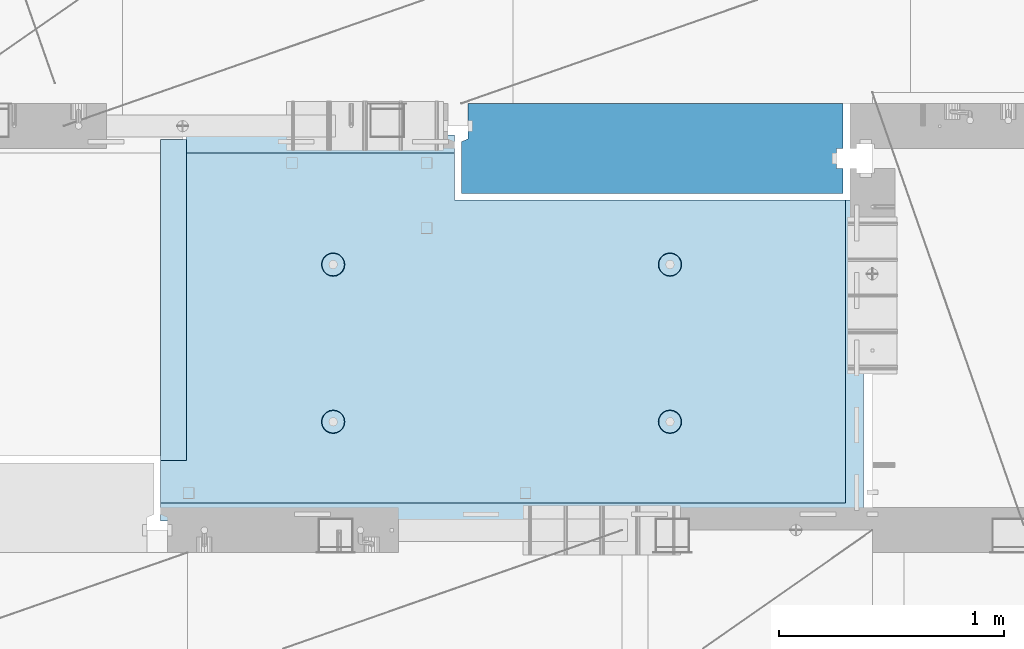
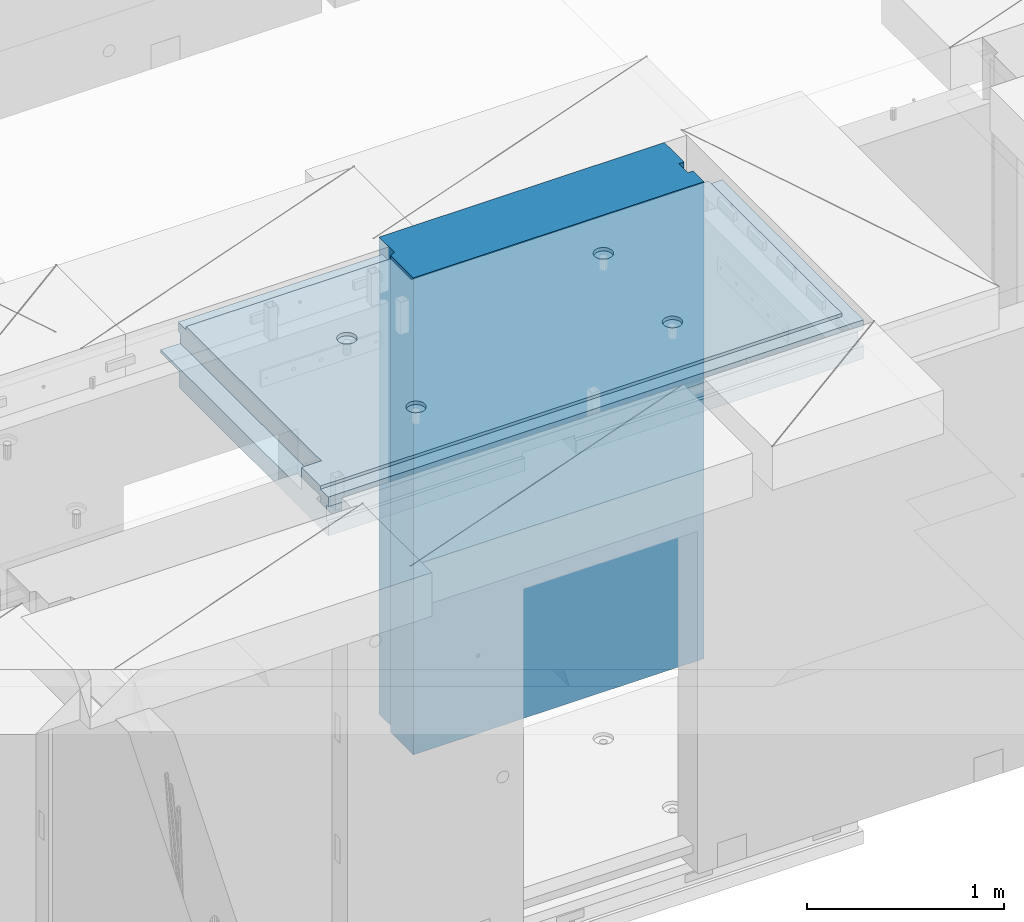
# One storey, part 209 of 352: 1 plate, 1 slab, 2 elements without a shape of their own.
"""IFC2X3 building model written with IfcOpenShell, lengths in millimetres."""

from ifc_helpers import new_model, si_unit, frame, origin_with_axes, place, context, subcontext, project, spatial, faceted_brep, material, type_object, element, aggregate, save


model = new_model("IFC2X3")

# Units and contexts
model_context = context("Model", 3, precision=1e-05, world=origin_with_axes())
body_context = subcontext(model_context, "Body", "Model", "MODEL_VIEW")
ifc_project = project(units=[si_unit("LENGTHUNIT", "METRE", prefix="MILLI"), si_unit("AREAUNIT", "SQUARE_METRE"), si_unit("VOLUMEUNIT", "CUBIC_METRE"), si_unit("MASSUNIT", "GRAM", prefix="KILO"), si_unit("TIMEUNIT", "SECOND"), si_unit("PLANEANGLEUNIT", "RADIAN"), si_unit("SOLIDANGLEUNIT", "STERADIAN"), si_unit("THERMODYNAMICTEMPERATUREUNIT", "DEGREE_CELSIUS"), si_unit("LUMINOUSINTENSITYUNIT", "LUMEN")], contexts=[model_context])

# Site, building, storey
site_placement = place(None, origin_with_axes())
site = spatial("IfcSite", under=ifc_project, at=site_placement, CompositionType="ELEMENT")
building_placement = place(site_placement, origin_with_axes())
building = spatial("IfcBuilding", under=site, at=building_placement, CompositionType="ELEMENT")
storey_placement = place(building_placement, origin_with_axes())
storey = spatial("IfcBuildingStorey", under=building, at=storey_placement, Name="6", CompositionType="ELEMENT", Elevation=0.0)

# Assembly, slab
assembly_1_placement = place(storey_placement, origin_with_axes())
assembly_1 = element("IfcElementAssembly", 1, at=assembly_1_placement, inside=storey, AssemblyPlace="NOTDEFINED", PredefinedType="REINFORCEMENT_UNIT")
ifc_material_1 = material(Name="CONCRETE/C25/30")
slab_type = type_object("IfcSlabType", PredefinedType="NOTDEFINED")
slab_placement = place(assembly_1_placement, frame((26570.0059390845, 15220.0026483125, 99620.0), z_axis=(-0.999999999997437, -2.26400000064461e-06, 0.0), x_axis=(-1.19799915409591e-06, 0.999999999999282, 0.0)))
slab = element("IfcSlab", 2, at=slab_placement, type_object=slab_type, material=ifc_material_1, PredefinedType="FLOOR", context=body_context, shape_type="Brep", body=[
    faceted_brep([(260.000036693442, 30.0, 20.0001116859203), (260.00040878505, 30.0, 210.00282380305), (760.000392750888, 30.0, 210.001882803081), (760.000035167954, 30.0, 20.0003241859195), (259.999997532928, 50.0008466322761, 0.000110715616756352), (259.999997531775, 130.0, 4.72937244921923e-11), (260.00040878505, 130.0, 210.00282380305), (260.00003669344, 50.0008466322906, 20.0001116859239), (760.000392750888, 130.0, 210.001882803081), (759.999997530887, 50.0009701322706, 0.00188280345173553), (760.000035167954, 50.0009701322851, 20.0003241859267), (759.999997530887, 130.0, 1.4915713109076e-10), (0.0, 130.0, -1.81898940354586e-12), (0.0, 50.0007830199902, -3.63797880709171e-12), (2.23492861550767e-06, 50.0007830199902, 20.0000012144774), (0.00314200731554592, 50.0009709416772, 1679.99820316408), (0.00316042736994859, 130.0, 1679.99820316404), (20.0042037197236, 50.0007871208509, 20.0000019346335), (20.0050448999082, 50.0009732451872, 1679.9981655205), (20.0051981998968, 30.0, 1979.99816552074), (210.003723882246, 30.0, 1979.99780794351), (210.003159282247, 30.0, 1679.99780794404), (20.0050448999027, 30.0, 1679.9981655205), (20.0057858500695, 50.0011356208415, 3129.99855788155), (0.00588817475545511, 50.0011356208415, 3129.99536132812), (0.00371018100122456, 50.0010050132987, 1979.99820316354), (20.0051981998986, 50.0010068401461, 1979.99816552074), (1720.00727399273, -49.9988643791585, 3014.99216831216), (1700.0058891816, -49.9988643791585, 3014.99217713277), (1700.0058891816, 9.99999999994179, 3014.99217713277), (270.007273993393, 9.99999999994179, 3014.99280776216), (270.007273993393, -130.000000000058, 3014.99280776216), (1640.00591170533, -130.000000000058, 3014.99220359276), (1640.00591170533, -110.000000000058, 3014.99220359276), (1720.00727399273, -110.000000000058, 3014.99216831216), (1700.00578510373, 9.99999999994179, 3129.99536132812), (270.007324709519, 9.99999999994179, 3129.99536132812), (1700.00588013352, 9.99999999994179, 3024.99005271558), (270.007324709519, -130.0, 3129.99536132812), (0.0, -49.9992169800098, -3.63797880709171e-12), (1.81898940354586e-12, -110.000000000058, 0.0), (0.00588817475545511, -110.0, 3129.99536132812), (0.00588817475545511, -49.9988643791585, 3129.99536132812), (2.27349282795331e-05, -49.9992169800098, 20.000001214441), (40.0000000237706, -110.0, 0.00323799208854325), (40.0000056179106, -110.0, 80.000116817555), (80.0001648500238, -110.0, 80.0001140175445), (80.0058896111077, -110.0, 3129.99536132811), (80.0001648500238, -130.0, 80.0001140175445), (80.0058896111077, -130.0, 3129.99536132812), (458.262860973307, -110.000000000015, 813.90255309167), (472.201273869185, -110.000000000015, 821.004529187678), (483.262860973307, -110.000000000015, 832.066116291804), (490.364837069317, -110.000000000015, 846.004529187678), (492.812011254558, -110.000000000015, 861.455378906427), (490.364837069317, -110.000000000015, 876.906228625172), (483.262860973307, -110.000000000015, 890.844641521049), (472.201273869185, -110.000000000015, 901.906228625176), (458.262860973306, -110.000000000015, 909.008204721184), (442.81201125456, -110.000000000015, 911.455378906427), (427.361161535811, -110.000000000015, 909.008204721184), (413.422748639936, -110.000000000015, 901.906228625176), (402.361161535813, -110.000000000015, 890.844641521046), (395.259185439802, -110.000000000015, 876.906228625176), (392.81201125456, -110.000000000015, 861.455378906427), (395.259185439802, -110.000000000015, 846.004529187681), (402.361161535813, -110.000000000015, 832.0661162918), (413.422748639936, -110.000000000015, 821.004529187678), (427.361161535813, -110.000000000015, 813.90255309167), (442.812011254558, -110.000000000015, 811.455378906427), (458.965172324157, -130.0, 811.741061009179), (442.812011254558, -130.0, 809.182651633699), (473.537149442574, -130.0, 819.165854200462), (485.101535960521, -130.0, 830.730240718414), (492.526329151806, -130.0, 845.302217836826), (495.084738527285, -130.0, 861.45537890643), (492.526329151804, -130.0, 877.608539976027), (485.101535960521, -130.0, 892.180517094443), (473.537149442574, -130.0, 903.744903612387), (458.965172324157, -130.0, 911.16969680367), (442.81201125456, -130.0, 913.728106179151), (426.658850184962, -130.0, 911.169696803674), (412.086873066544, -130.0, 903.744903612391), (400.522486548598, -130.0, 892.180517094443), (393.097693357315, -130.0, 877.608539976027), (390.539283981834, -130.0, 861.455378906427), (393.097693357317, -130.0, 845.302217836826), (400.522486548598, -130.0, 830.730240718414), (412.086873066544, -130.0, 819.165854200462), (426.658850184962, -130.0, 811.741061009183), (1158.26361347154, -110.000000000058, 2313.90608356011), (1172.20202636741, -110.000000000058, 2321.00805965612), (1183.26361347154, -110.000000000058, 2332.06964676024), (1190.36558956755, -110.000000000058, 2346.00805965611), (1192.81276375279, -110.000000000058, 2361.45890937486), (1190.36558956755, -110.000000000058, 2376.90975909361), (1183.26361347154, -110.000000000058, 2390.84817198949), (1172.20202636741, -110.000000000058, 2401.90975909361), (1158.26361347154, -110.000000000058, 2409.01173518962), (1142.81276375279, -110.000000000058, 2411.45890937487), (1127.36191403404, -110.000000000058, 2409.01173518962), (1113.42350113817, -110.000000000058, 2401.90975909361), (1102.36191403404, -110.000000000058, 2390.84817198948), (1095.25993793803, -110.000000000058, 2376.90975909361), (1092.81276375279, -110.000000000058, 2361.45890937486), (1095.25993793803, -110.000000000058, 2346.00805965612), (1102.36191403404, -110.000000000058, 2332.06964676024), (1113.42350113817, -110.000000000058, 2321.00805965611), (1127.36191403405, -110.000000000058, 2313.90608356011), (1142.81276375279, -110.000000000058, 2311.45890937486), (1158.96592482239, -130.000000000044, 2311.74459147762), (1142.81276375279, -130.000000000044, 2309.18618210214), (1173.5379019408, -130.000000000044, 2319.1693846689), (1185.10228845875, -130.000000000044, 2330.73377118685), (1192.52708165004, -130.000000000044, 2345.30574830526), (1195.08549102551, -130.000000000044, 2361.45890937486), (1192.52708165004, -130.000000000044, 2377.61207044447), (1185.10228845875, -130.000000000044, 2392.18404756288), (1173.5379019408, -130.000000000044, 2403.74843408083), (1158.96592482239, -130.000000000044, 2411.17322727211), (1142.81276375279, -130.000000000044, 2413.73163664759), (1126.65960268319, -130.000000000044, 2411.17322727211), (1112.08762556478, -130.000000000044, 2403.74843408083), (1100.52323904683, -130.000000000044, 2392.18404756287), (1093.09844585554, -130.000000000044, 2377.61207044447), (1090.54003648007, -130.000000000044, 2361.45890937486), (1093.09844585555, -130.000000000044, 2345.30574830526), (1100.52323904683, -130.000000000044, 2330.73377118685), (1112.08762556478, -130.000000000044, 2319.1693846689), (1126.65960268319, -130.000000000044, 2311.74459147762), (1158.26322681425, -110.000000000029, 813.902566246979), (1172.20163971013, -110.000000000029, 821.004542342987), (1183.26322681425, -110.000000000029, 832.066129447114), (1190.36520291026, -110.000000000029, 846.004542342987), (1192.8123770955, -110.000000000029, 861.455392061736), (1190.36520291026, -110.000000000029, 876.906241780482), (1183.26322681425, -110.000000000029, 890.844654676363), (1172.20163971012, -110.000000000029, 901.906241780485), (1158.26322681425, -110.000000000029, 909.008217876493), (1142.8123770955, -110.000000000029, 911.455392061736), (1127.36152737675, -110.000000000029, 909.008217876493), (1113.42311448088, -110.000000000029, 901.906241780485), (1102.36152737675, -110.000000000029, 890.844654676359), (1095.25955128074, -110.000000000029, 876.906241780485), (1092.8123770955, -110.000000000029, 861.45539206174), (1095.25955128074, -110.000000000029, 846.004542342991), (1102.36152737675, -110.000000000029, 832.06612944711), (1113.42311448088, -110.000000000029, 821.004542342987), (1127.36152737675, -110.000000000029, 813.902566246979), (1142.8123770955, -110.000000000029, 811.455392061736), (1158.9655381651, -130.000000000029, 811.741074164489), (1142.8123770955, -130.000000000029, 809.182664789012), (1173.53751528352, -130.000000000029, 819.165867355772), (1185.10190180146, -130.000000000029, 830.730253873724), (1192.52669499275, -130.000000000029, 845.302230992136), (1195.08510436823, -130.000000000029, 861.45539206174), (1192.52669499275, -130.000000000029, 877.608553131337), (1185.10190180146, -130.000000000029, 892.180530249756), (1173.53751528351, -130.000000000029, 903.744916767697), (1158.9655381651, -130.000000000029, 911.16970995898), (1142.8123770955, -130.000000000029, 913.728119334461), (1126.6592160259, -130.000000000029, 911.169709958984), (1112.08723890749, -130.000000000029, 903.7449167677), (1100.52285238954, -130.000000000029, 892.180530249752), (1093.09805919825, -130.000000000029, 877.608553131337), (1090.53964982277, -130.000000000015, 861.455392061736), (1093.09805919826, -130.000000000015, 845.302230992136), (1100.52285238954, -130.000000000015, 830.730253873724), (1112.08723890749, -130.000000000015, 819.165867355776), (1126.6592160259, -130.000000000015, 811.741074164493), (458.263613472778, -110.000000000058, 2313.90740096011), (472.202026368655, -110.000000000058, 2321.00937705611), (483.263613472776, -110.000000000058, 2332.07096416024), (490.365589568788, -110.000000000058, 2346.00937705611), (492.812763754029, -110.000000000058, 2361.46022677486), (490.365589568788, -110.000000000058, 2376.91107649361), (483.263613472778, -110.000000000058, 2390.84948938949), (472.202026368655, -110.000000000058, 2401.91107649361), (458.263613472776, -110.000000000058, 2409.01305258962), (442.812763754029, -110.000000000058, 2411.46022677486), (427.361914035282, -110.000000000058, 2409.01305258962), (413.423501139407, -110.000000000058, 2401.91107649361), (402.361914035284, -110.000000000058, 2390.84948938949), (395.259937939272, -110.000000000058, 2376.91107649361), (392.812763754031, -110.000000000058, 2361.46022677486), (395.259937939272, -110.000000000058, 2346.00937705612), (402.361914035284, -110.000000000058, 2332.07096416024), (413.423501139407, -110.000000000058, 2321.00937705611), (427.361914035284, -110.000000000058, 2313.90740096011), (442.812763754029, -110.000000000058, 2311.46022677486), (458.965924823628, -130.000000000029, 2311.74590887762), (442.812763754029, -130.000000000029, 2309.18749950214), (473.537901942043, -130.000000000029, 2319.1707020689), (485.10228845999, -130.000000000029, 2330.73508858685), (492.527081651273, -130.000000000029, 2345.30706570526), (495.085491026754, -130.000000000029, 2361.46022677486), (492.527081651273, -130.000000000029, 2377.61338784446), (485.102288459992, -130.000000000029, 2392.18536496288), (473.537901942043, -130.000000000029, 2403.74975148082), (458.965924823628, -130.000000000029, 2411.1745446721), (442.812763754031, -130.000000000029, 2413.73295404758), (426.659602684433, -130.000000000029, 2411.17454467211), (412.087625566017, -130.000000000029, 2403.74975148082), (400.523239048071, -130.000000000029, 2392.18536496288), (393.098445856787, -130.000000000029, 2377.61338784446), (390.540036481307, -130.000000000029, 2361.46022677486), (393.098445856789, -130.000000000029, 2345.30706570526), (400.523239048067, -130.000000000029, 2330.73508858685), (412.087625566017, -130.000000000029, 2319.17070206891), (426.659602684433, -130.000000000029, 2311.74590887762), (1640.0069692709, -130.000000000058, 1820.00285259458), (1429.99412576448, -130.0, 80.0005450159842), (1430.00077693619, -130.000000000044, 1820.00324782623), (1640.0069692709, -110.000000000058, 1820.00285259458), (1720.00719314726, -110.000000000058, 1820.00270203416), (1720.00719416424, -49.9988643791585, 1820.00270203415), (1700.00697064704, -49.9988643791585, 1820.00273967458), (1430.00077693619, 129.999999999985, 1820.00324782623), (1720.00507313573, 130.0, 1820.00270203815), (1720.00696350816, 50.0011356208415, 1820.00270203459), (1700.00697064704, 50.0011356208415, 1820.00273967458), (1720.00548380367, 130.0, 2629.9953613439), (1720.00479630696, 50.0011356208415, 2629.99536134425), (1700.00623760369, 50.0011356208415, 2629.99539898154), (1700.00623760369, 30.0, 2629.99539898154), (1700.00578510373, 30.0, 3129.99535793147), (1510.00479630733, 130.0, 2629.99575656425), (1510.00479630733, 30.0, 2629.99575656425), (1510.00573730659, 130.0, 3129.99536132812), (1510.00573730659, 30.0, 3129.99536134176), (0.00588817475545511, 130.0, 3129.99536132812), (20.0057858500695, -49.9988643791585, 3129.99855788155), (0.00372479000361636, 130.0, 1979.99820316351), (210.003723882246, 130.0, 1979.99780794351), (210.003159282247, 130.0, 1679.99780794404), (20.0042037196527, -49.9988643791585, 20.0000019345935), (20.0041864226587, -49.9992128791491, 7.34271452529356e-07), (1429.99419217423, -49.9988643791585, 20.0006089333838), (1429.99420067423, -49.9988643791585, 0.000608933383773547), (80.0000146155362, -110.0, 0.000114017555461032), (1429.99735169022, -110.0, 7.40013310860377e-05), (1429.99412576448, -110.0, 80.0005450159842), (1429.99416747423, 50.0011356208415, 20.0006089334311), (1429.99417597423, 50.0011356208415, 0.000608933431067271), (1429.99735169022, 130.0, 2.80124368146062e-10), (20.0041864225386, 50.0007871208509, -3.03407432511449e-09)], [[[0, 1, 2, 3]], [[4, 5, 6, 1, 0, 7]], [[8, 2, 1, 6]], [[9, 10, 3, 2, 8, 11]], [[12, 13, 14, 15, 16]], [[14, 17, 18, 15]], [[19, 20, 21, 22]], [[23, 24, 25, 26]], [[27, 28, 29, 30, 31, 32, 33, 34]], [[35, 36, 30, 29, 37]], [[31, 30, 36, 38]], [[39, 40, 41, 42, 43]], [[44, 45, 46, 47, 41, 40]], [[48, 49, 47, 46]], [[50, 51, 52, 53, 54, 55, 56, 57, 58, 59, 60, 61, 62, 63, 64, 65, 66, 67, 68, 69]], [[70, 50, 69, 71]], [[72, 51, 50, 70]], [[73, 52, 51, 72]], [[74, 53, 52, 73]], [[75, 54, 53, 74]], [[76, 55, 54, 75]], [[77, 56, 55, 76]], [[78, 57, 56, 77]], [[79, 58, 57, 78]], [[80, 59, 58, 79]], [[81, 60, 59, 80]], [[82, 61, 60, 81]], [[83, 62, 61, 82]], [[84, 63, 62, 83]], [[85, 64, 63, 84]], [[86, 65, 64, 85]], [[87, 66, 65, 86]], [[88, 67, 66, 87]], [[89, 68, 67, 88]], [[71, 69, 68, 89]], [[90, 91, 92, 93, 94, 95, 96, 97, 98, 99, 100, 101, 102, 103, 104, 105, 106, 107, 108, 109]], [[110, 90, 109, 111]], [[112, 91, 90, 110]], [[113, 92, 91, 112]], [[114, 93, 92, 113]], [[115, 94, 93, 114]], [[116, 95, 94, 115]], [[117, 96, 95, 116]], [[118, 97, 96, 117]], [[119, 98, 97, 118]], [[120, 99, 98, 119]], [[121, 100, 99, 120]], [[122, 101, 100, 121]], [[123, 102, 101, 122]], [[124, 103, 102, 123]], [[125, 104, 103, 124]], [[126, 105, 104, 125]], [[127, 106, 105, 126]], [[128, 107, 106, 127]], [[129, 108, 107, 128]], [[111, 109, 108, 129]], [[130, 131, 132, 133, 134, 135, 136, 137, 138, 139, 140, 141, 142, 143, 144, 145, 146, 147, 148, 149]], [[150, 130, 149, 151]], [[152, 131, 130, 150]], [[153, 132, 131, 152]], [[154, 133, 132, 153]], [[155, 134, 133, 154]], [[156, 135, 134, 155]], [[157, 136, 135, 156]], [[158, 137, 136, 157]], [[159, 138, 137, 158]], [[160, 139, 138, 159]], [[161, 140, 139, 160]], [[162, 141, 140, 161]], [[163, 142, 141, 162]], [[164, 143, 142, 163]], [[165, 144, 143, 164]], [[166, 145, 144, 165]], [[167, 146, 145, 166]], [[168, 147, 146, 167]], [[169, 148, 147, 168]], [[151, 149, 148, 169]], [[170, 171, 172, 173, 174, 175, 176, 177, 178, 179, 180, 181, 182, 183, 184, 185, 186, 187, 188, 189]], [[190, 170, 189, 191]], [[192, 171, 170, 190]], [[193, 172, 171, 192]], [[194, 173, 172, 193]], [[195, 174, 173, 194]], [[196, 175, 174, 195]], [[197, 176, 175, 196]], [[198, 177, 176, 197]], [[199, 178, 177, 198]], [[200, 179, 178, 199]], [[201, 180, 179, 200]], [[202, 181, 180, 201]], [[203, 182, 181, 202]], [[204, 183, 182, 203]], [[205, 184, 183, 204]], [[206, 185, 184, 205]], [[207, 186, 185, 206]], [[208, 187, 186, 207]], [[209, 188, 187, 208]], [[191, 189, 188, 209]], [[210, 32, 31, 38, 49, 48, 211, 212], [208, 207, 206, 205, 204, 203, 202, 201, 200, 199, 198, 197, 196, 195, 194, 193, 192, 190, 191, 209], [168, 167, 166, 165, 164, 163, 162, 161, 160, 159, 158, 157, 156, 155, 154, 153, 152, 150, 151, 169], [128, 127, 126, 125, 124, 123, 122, 121, 120, 119, 118, 117, 116, 115, 114, 113, 112, 110, 111, 129], [88, 87, 86, 85, 84, 83, 82, 81, 80, 79, 78, 77, 76, 75, 74, 73, 72, 70, 71, 89]], [[33, 32, 210, 213]], [[34, 33, 213, 214]], [[27, 34, 214, 215]], [[28, 27, 215, 216]], [[214, 213, 210, 212, 217, 218, 219, 220, 216, 215]], [[219, 218, 221, 222]], [[220, 219, 222, 223]], [[35, 37, 29, 28, 216, 220, 223, 224, 225]], [[222, 221, 226, 227, 224, 223]], [[228, 229, 227, 226]], [[224, 227, 229, 225]], [[228, 230, 24, 23, 231, 42, 41, 47, 49, 38, 36, 35, 225, 229]], [[24, 230, 232, 25]], [[233, 20, 19, 26, 25, 232]], [[234, 21, 20, 233]], [[16, 15, 18, 22, 21, 234]], [[17, 235, 231, 23, 26, 19, 22, 18]], [[43, 42, 231, 235]], [[236, 39, 43, 235, 237, 238]], [[239, 44, 40, 39, 236, 238, 240]], [[46, 45, 44, 239, 240, 241]], [[48, 46, 241, 211]], [[240, 238, 237, 242, 243, 244, 217, 212, 211, 241]], [[244, 243, 9, 11]], [[6, 5, 12, 16, 234, 233, 232, 230, 228, 226, 221, 218, 217, 244, 11, 8]], [[245, 13, 12, 5, 4]], [[17, 14, 13, 245, 4, 7]], [[242, 237, 235, 17, 7, 0, 3, 10]], [[243, 242, 10, 9]]]),
])
aggregate(assembly_1, [slab])

# Assembly, plate
assembly_2_placement = place(storey_placement, origin_with_axes())
assembly_2 = element("IfcElementAssembly", 3, at=assembly_2_placement, inside=storey, Name="Steel Assembly", AssemblyPlace="NOTDEFINED", PredefinedType="NOTDEFINED")
ifc_material_2 = material()
plate_type = type_object("IfcPlateType", PredefinedType="NOTDEFINED")
plate_placement = place(assembly_2_placement, frame((24780.0, 16680.0, 98255.6000003815), z_axis=(0.0, 1.0, 0.0), x_axis=(1.0, 0.0, 0.0)))
plate = element("IfcPlate", 4, at=plate_placement, type_object=plate_type, material=ifc_material_2, context=body_context, shape_type="Brep", body=[
    faceted_brep([(1699.99914550781, -1475.0, 110.0), (1699.99914550781, 1475.0, 110.0), (1669.99914550781, 1475.0, 110.0), (1669.99914550781, -1475.00000000001, 110.0), (1669.99914550781, 1475.0, 200.0), (1669.99914550781, -1475.00000000001, 200.0), (1699.99914550781, -1475.0, 200.0), (1699.99914550781, 1475.0, 200.0), (1699.99914550781, -1475.0, 3.63797880709171e-12), (0.0, -1475.0, 0.0), (0.0, 1475.0, 0.0), (1699.99914550781, 1475.0, 3.63797880709171e-12), (0.0, -1475.0, 230.0), (0.0, 1475.0, 230.0), (30.0, -1475.0, 243.0), (30.0, 1475.0, 243.0), (30.0, -1475.0, 400.0), (30.0, 1475.0, 400.0), (1699.99914550781, -1475.0, 400.0), (1699.99914550781, 1475.0, 400.0)], [[[0, 1, 2, 3]], [[3, 2, 4, 5]], [[6, 5, 4, 7]], [[8, 9, 10, 11]], [[10, 9, 12, 13]], [[14, 15, 13, 12]], [[16, 17, 15, 14]], [[18, 19, 17, 16]], [[19, 18, 6, 7]], [[2, 1, 11, 10, 13, 15, 17, 19, 7, 4]], [[8, 11, 1, 0]], [[18, 16, 14, 12, 9, 8, 0, 3, 5, 6]]]),
])
aggregate(assembly_2, [plate])

save(model, "model.ifc")
